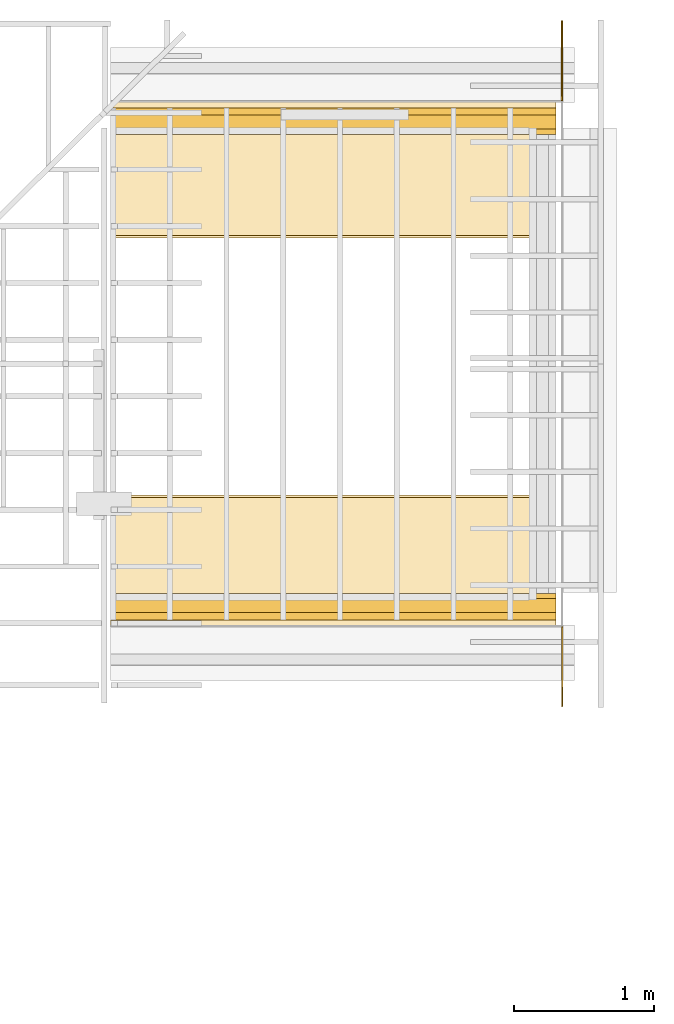
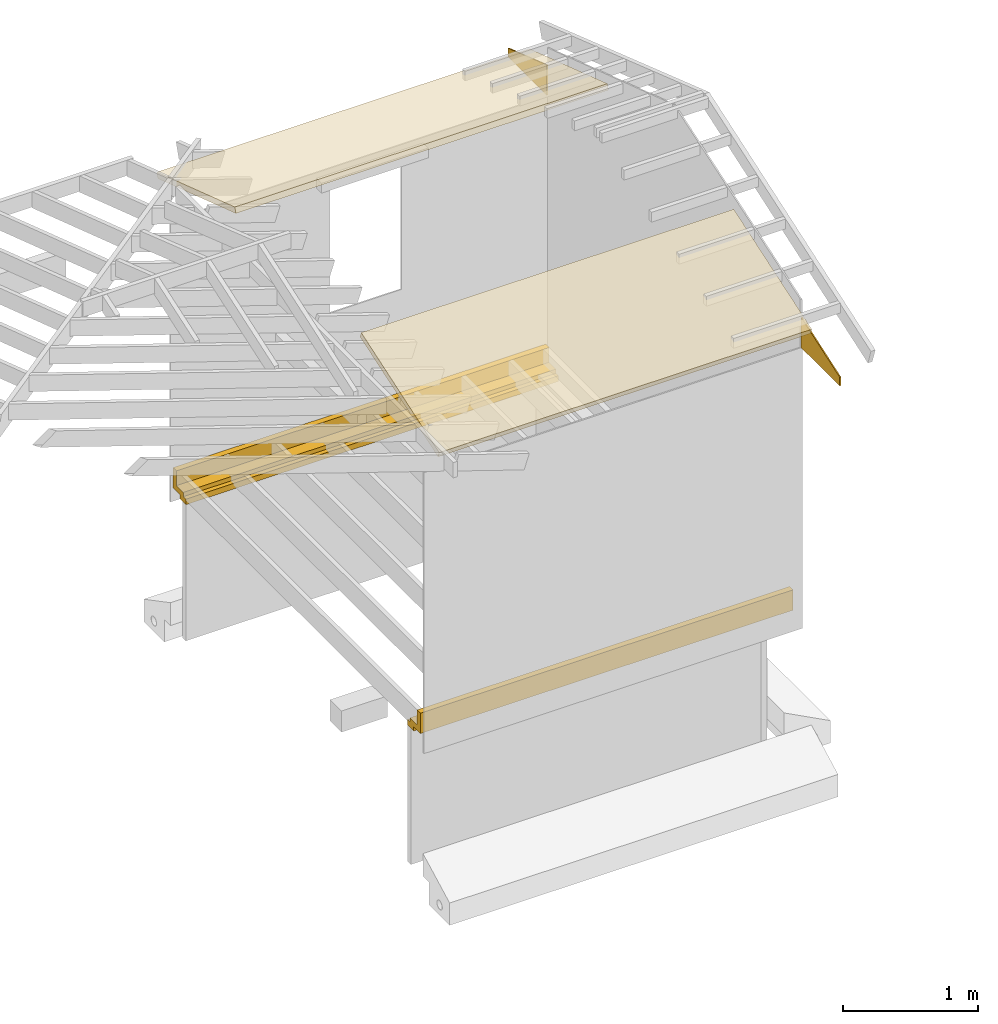
# Not in any storey, part 6 of 8: 6 coverings, 2 openings.
"""IFC4 model written with IfcOpenShell, lengths in feet."""

from ifc_helpers import new_model, entity, si_unit, converted_unit, frame, origin_with_axes, origin_2d_with_axis, place, context, subcontext, project, polyline, line, indexed_curve, outline, extrude, material, layer, layer_set, layer_usage, type_object, element, save


model = new_model("IFC4")

# Units and contexts
model_context = context("Model", 3, precision=1e-05, world=origin_with_axes())
plan_context = context("Plan", 2, precision=1e-05, world=origin_2d_with_axis())
context_of_model_1 = context(None, 3, precision=1e-05, world=origin_with_axes())
context_of_model_2 = context(None, 3, precision=1e-05, world=origin_with_axes())
body_context = subcontext(model_context, "Body", "Model", "MODEL_VIEW")
ifc_project = project(units=[converted_unit("PLANEANGLEUNIT", "degree", entity("IfcReal", 0.0174532925199433), si_unit("PLANEANGLEUNIT", "RADIAN"), dimensions=[0, 0, 0, 0, 0, 0, 0]), converted_unit("AREAUNIT", "square foot", entity("IfcReal", 0.09290304), si_unit("AREAUNIT", "SQUARE_METRE"), dimensions=[2, 0, 0, 0, 0, 0, 0]), converted_unit("LENGTHUNIT", "foot", entity("IfcReal", 0.3048), si_unit("LENGTHUNIT", "METRE"), dimensions=[1, 0, 0, 0, 0, 0, 0]), converted_unit("VOLUMEUNIT", "cubic foot", entity("IfcReal", 0.0283168467116885), si_unit("VOLUMEUNIT", "CUBIC_METRE"), dimensions=[3, 0, 0, 0, 0, 0, 0])], contexts=[model_context, plan_context, context_of_model_1, context_of_model_2])

# Covering, opening
ifc_material_1 = material()
ifc_layer = layer(ifc_material_1, 0.0328083989501312)
ifc_layer_set = layer_set([ifc_layer])
ifc_layer_usage_1 = layer_usage(ifc_layer_set, "AXIS2", "POSITIVE", 0.0)
covering_type = type_object("IfcCoveringType", Name="COV10", PredefinedType="NOTDEFINED", material=ifc_layer_set)
covering_1_placement = place(None, frame((-0.285812093829858, -5.07629019381806, 7.1824081926521), z_axis=(0.0, 0.0, 1.0), x_axis=(7.54979012640431e-08, 0.999999999999997, 0.0)))
covering_1 = element("IfcCovering", 1, at=covering_1_placement, type_object=covering_type, material=ifc_layer_usage_1, Name="Covering", context=body_context, shape_type="SweptSolid", body=[
    extrude(outline(indexed_curve([(0.0, 0.0), (0.0, 0.0328083989501312), (2.00000000376181, 0.0328083989501312), (2.00000000376181, 0.0), (0.0, 0.0)], self_intersect=False)), origin_with_axes(), (0.0, 0.0, 1.0), 1.00000001235897),
])
opening_1_placement = place(covering_1_placement, frame((-3.14523560302233e-09, 0.041659892074705, 0.0), z_axis=(1.1920927889264e-07, -0.999999999999992, -4.37113882867378e-08), x_axis=(0.999999999999944, 1.19209289550775e-07, -3.13916501681872e-07)))
element("IfcOpeningElement", 2, at=opening_1_placement, cuts=covering_1, Name="Opening", context=body_context, shape_type="SweptSolid", body=[
    extrude(outline(indexed_curve([(-2.02263473212875, 1.34158048416999), (-2.02263512323535, 9.66933223486705e-07), (7.30423479064264e-07, 0.260704712761356), (5.57641631908477e-07, 1.34158038639334), (-1.87500118427076, 0.900004323073259), (-1.87500216203725, 2.81107863729081e-07)], segments=[line(3, 5), line(5, 6), line(6, 2), line(2, 1), line(1, 4), line(4, 3)], self_intersect=False)), frame((0.0, 0.0, -0.820209973753281), z_axis=(0.0, 0.0, -1.0), x_axis=(-1.0, 0.0, 0.0)), (0.0, 0.0, -1.0), 1.64041994750656),
])

ifc_layer_usage_2 = layer_usage(ifc_layer_set, "AXIS2", "POSITIVE", 0.0)
covering_2_placement = place(None, frame((-0.327475896970494, 11.0432474319078, 7.1824081926521), z_axis=(0.0, 0.0, 1.0), x_axis=(1.19248806385031e-08, -1.0, 0.0)))
covering_2 = element("IfcCovering", 3, at=covering_2_placement, type_object=covering_type, material=ifc_layer_usage_2, Name="Covering", context=body_context, shape_type="SweptSolid", body=[
    extrude(outline(indexed_curve([(0.0, 0.0), (0.0, 0.0328083989501312), (2.00000000376181, 0.0328083989501312), (2.00000000376181, 0.0), (0.0, 0.0)], self_intersect=False)), origin_with_axes(), (0.0, 0.0, 1.0), 1.00000001235897),
])
opening_2_placement = place(covering_2_placement, frame((7.86516709154243e-07, 0.360886128790413, 0.0), z_axis=(5.56362618198135e-08, 0.999999999999997, -4.37113882867378e-08), x_axis=(0.999999999999979, -5.56362689252399e-08, -1.94707212131103e-07)))
element("IfcOpeningElement", 4, at=opening_2_placement, cuts=covering_2, Name="Opening", context=body_context, shape_type="SweptSolid", body=[
    extrude(outline(indexed_curve([(-2.46613650653619, -1.71011318684876), (1.95553296507187e-07, -1.71011299129546), (2.46309546104161e-07, -0.260680073045996), (-2.46613650653619, -3.42218268887577e-07), (-1.87499668654494, -0.900214933973598), (-1.87499688209824, -3.01533403087534e-07)], segments=[line(2, 1), line(1, 4), line(4, 6), line(6, 5), line(5, 3), line(3, 2)], self_intersect=False)), frame((0.0, 0.0, -0.820209973753281), z_axis=(0.0, 0.0, -1.0), x_axis=(-1.0, 0.0, 0.0)), (0.0, 0.0, -1.0), 1.64041994750656),
])

# Coverings
ifc_material_2 = material(Category="InsulationBattVert")
covering_3_placement = place(None, frame((-10.92122530374, 9.00158027964314, -0.062500006883476), z_axis=(0.999999999999997, 0.0, 7.54979012640431e-08), x_axis=(7.54979012640431e-08, 0.0, -0.999999999999997)))
element("IfcCovering", 5, at=covering_3_placement, material=ifc_material_2, Name="Plane", PredefinedType="INSULATION", context=body_context, shape_type="SweptSolid", body=[
    extrude(outline(polyline([(-0.174980050837743, -0.0291596823115283), (0.158320596622513, -0.0291596823115283), (0.158320535512108, -0.46669195095698), (0.324987090165847, -0.46669195095698), (0.324987187942495, 0.137506795954204), (-0.00831346868432256, 0.137506844842528), (-0.00831345035120102, 0.262506809721156), (-0.300014836425231, 0.262505049741487), (-0.300013687549614, 0.0958382934234117), (-0.174980026393581, 0.0958390084151521), (-0.174980050837743, -0.0291596823115283)])), frame((0.466692684281842, -0.324987163498333, 10.4687587795608), z_axis=(8.10393544270482e-07, 0.0, -1.0), x_axis=(1.46679354884327e-07, 1.0, 0.0)), (-4.65997851417654e-10, -8.87402336502419e-07, 0.999999940395355), 10.4687589662962),
])
covering_4_placement = place(None, frame((-10.9212260859532, -3.03462421487323, -0.0624112256868618), z_axis=(1.50995802528085e-07, 0.0, -0.999999999999989), x_axis=(-0.999999999999989, 0.0, -1.50995802528085e-07)))
element("IfcCovering", 6, at=covering_4_placement, material=ifc_material_2, Name="Plane", PredefinedType="INSULATION", context=body_context, shape_type="SweptSolid", body=[
    extrude(outline(polyline([(-0.262480581135262, 0.00833306373573664), (-0.137478709611993, 0.00833306373573664), (-0.137478709611993, -0.325000021127578), (0.466599992019298, -0.325000021127578), (0.466599992019298, -0.158333527584245), (0.0291724941079698, -0.158333527584245), (0.0291724941079698, 0.174999642833637), (-0.095813146491689, 0.174999642833637), (-0.095813146491689, 0.300000829920368), (-0.262480581135262, 0.300000829920368), (-0.262480581135262, 0.00833306373573664)])), frame((1.867863227752e-07, 0.325000021127578, 0.466688773215912), z_axis=(1.0, -3.2417365218862e-06, -9.66185071944563e-14), x_axis=(0.0, 0.0, -1.0)), (-1.49437610730274e-07, -3.23940116686572e-06, -0.999999940395355), 10.4687589663472),
])
ifc_material_3 = material(Category="InsulationBattVert")
covering_5_placement = place(None, frame((-10.9212245215268, -3.48046070008766, 8.21196813908775), z_axis=(0.999999999999999, 2.98922415709057e-08, 4.14694660832992e-08), x_axis=(4.1469466205156e-08, -0.948710802004981, -0.316145242189511)))
element("IfcCovering", 7, at=covering_5_placement, material=ifc_material_3, Name="Plane", PredefinedType="INSULATION", context=body_context, shape_type="SweptSolid", body=[
    extrude(outline(indexed_curve([(-0.32498689461255, 4.02915978369125), (-0.158320621066675, 4.02915978369125), (-0.158320621066675, 0.0291596364787244), (-0.32498689461255, 0.0291596853670486)], segments=[line(4, 1), line(1, 2), line(2, 3), line(3, 4)], self_intersect=False)), frame((0.466691853180332, -0.324987187942495, -1.86735409870511e-07), z_axis=(8.10393544270482e-07, 4.83032193345119e-14, -1.0), x_axis=(0.0, -1.0, -1.74855416875275e-14)), (-1.74838120462492e-14, -8.89782256763283e-07, -0.999999940395355), 10.4687589662963),
])
covering_6_placement = place(None, frame((-10.9212245215268, -3.48046070008766, 8.21196813908775), z_axis=(0.999999999999999, 2.98922415709057e-08, 4.14694660832992e-08), x_axis=(4.1469466205156e-08, -0.948710802004981, -0.316145242189511)))
element("IfcCovering", 8, at=covering_6_placement, material=ifc_material_3, Name="Plane", PredefinedType="INSULATION", context=body_context, shape_type="SweptSolid", body=[
    extrude(outline(indexed_curve([(-4.63518140509998, 12.9634939779447), (-2.23573815478428, 9.76307654943992), (-2.10238762414987, 9.86305278117262), (-4.50183126557218, 13.0634702096774)], segments=[line(4, 1), line(1, 2), line(2, 3), line(3, 4)], self_intersect=False)), frame((0.466691853180332, -0.324987187942495, -1.86735409870511e-07), z_axis=(8.10393544270482e-07, 4.83032193345119e-14, -1.0), x_axis=(0.0, -1.0, -1.74855416875275e-14)), (-1.74838120462492e-14, -8.89782256763283e-07, -0.999999940395355), 10.4687589662963),
])

save(model, "model.ifc")
